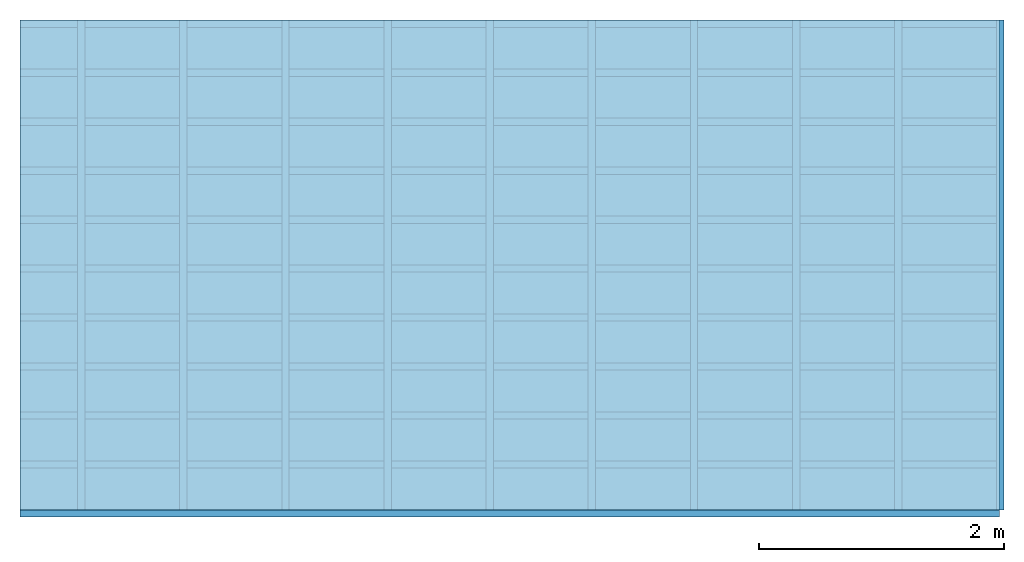
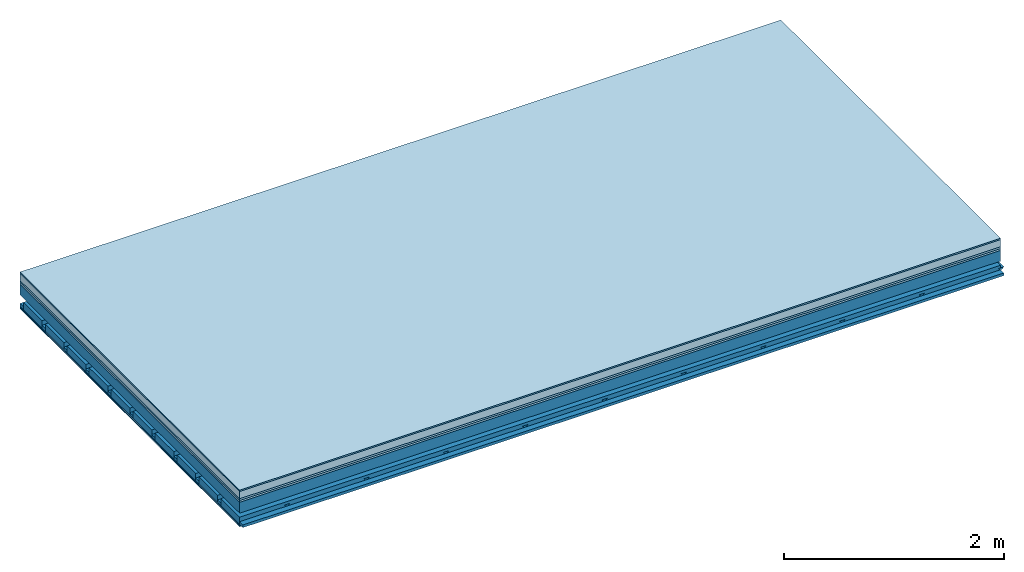
# One storey: 7 plates, 4 members, 1 element without a shape of its own.
"""IFC4 building model written with IfcOpenShell, lengths in metres."""

from ifc_helpers import new_model, si_unit, derived_unit, direction, frame, frame_2d, origin, origin_with_axes, place, context, project, spatial, polyline, rectangle, outline, extrude, material, layer, layer_set, type_object, element, aggregate, save


model = new_model("IFC4")

# Units and contexts
plan_context = context("Plan", 3, precision=1e-05, world=origin(), true_north=direction((0.0, 1.0)))
model_context = context("Model", 3, precision=1e-05, world=origin(), true_north=direction((0.0, 1.0)))
ifc_project = project(units=[si_unit("LENGTHUNIT", "METRE"), derived_unit("SOUNDPRESSUREUNIT", [(si_unit("PRESSUREUNIT", "PASCAL", prefix="MICRO"), 0)]), si_unit("ENERGYUNIT", "JOULE", prefix="MEGA"), si_unit("MASSUNIT", "GRAM", prefix="KILO"), derived_unit("THERMALTRANSMITTANCEUNIT", [(si_unit("POWERUNIT", "WATT"), 1), (si_unit("AREAUNIT", "SQUARE_METRE"), -1), (si_unit("THERMODYNAMICTEMPERATUREUNIT", "KELVIN"), -1)]), derived_unit("AREADENSITYUNIT", [(si_unit("MASSUNIT", "GRAM", prefix="KILO"), 1), (si_unit("AREAUNIT", "SQUARE_METRE"), -1)]), derived_unit("USERDEFINED", [(si_unit("ENERGYUNIT", "JOULE", prefix="MEGA"), 1), (si_unit("AREAUNIT", "SQUARE_METRE"), -1)])], contexts=[plan_context, model_context])

# Site, building, storey
site = spatial("IfcSite", under=ifc_project)
building_placement = place(None, origin())
building = spatial("IfcBuilding", under=site, at=building_placement)
storey_placement = place(building_placement, origin())
storey = spatial("IfcBuildingStorey", under=building, at=storey_placement)

# Slab, members, plates
ifc_material_1 = material(Category="11.013")
ifc_layer_1 = layer(ifc_material_1, 0.015, Name="Flooring")
ifc_material_2 = material(Name="Cement screed", Category="04.006")
ifc_layer_2 = layer(ifc_material_2, 0.08, Name="On-material")
ifc_material_3 = material(Name="Wood fiber generic product", Category="10.009")
ifc_layer_3 = layer(ifc_material_3, 0.02, Name="Impact sound insulation")
ifc_material_4 = material(Category="10.004")
ifc_layer_4 = layer(ifc_material_4, 0.02, Name="Additional insulation")
ifc_material_5 = material(Name="no composite action")
ifc_layer_5 = layer(ifc_material_5, 0.0, Name="Bond")
ifc_layer_6 = layer(None, 0.12, Name="Supporting structure")
ifc_layer_7 = layer(ifc_material_5, 0.0, Name="Bond")
ifc_layer_8 = layer(None, 0.095, Name="Coupling")
ifc_layer_9 = layer(None, 0.03, Name="Battens / profiles")
ifc_material_6 = material(Name="Plasterboard type A", Category="03.008")
ifc_layer_10 = layer(ifc_material_6, 0.0125, Name="Ceiling covering 1st layer")
ifc_layer_11 = layer(ifc_material_6, 0.0125, Name="Ceiling covering layer 2")
ifc_material_7 = material(Category="04.001")
ifc_layer_12 = layer(ifc_material_7, 0.003, Name="Surface / treatment")
ifc_layer_set = layer_set([ifc_layer_1, ifc_layer_2, ifc_layer_3, ifc_layer_4, ifc_layer_5, ifc_layer_6, ifc_layer_7, ifc_layer_8, ifc_layer_9, ifc_layer_10, ifc_layer_11, ifc_layer_12])
slab_type = type_object("IfcSlabType", Name="A2150", PredefinedType="NOTDEFINED", material=ifc_layer_set)
slab_placement = place(None, frame((0.0, 0.0, 0.0), z_axis=(0.0, 0.0, -1.0), x_axis=(1.0, 0.0, 0.0)))
slab = element("IfcSlab", 1, at=slab_placement, inside=storey, type_object=slab_type, material=ifc_layer_set, Name="Slab #1")
ifc_material_8 = material(Name="Solid timber panel")
member_1_placement = place(slab_placement, origin())
member_1 = element("IfcMember", 2, at=member_1_placement, material=ifc_material_8, Name="Supporting structure", context=plan_context, shape_type="SweptSolid", body=[
    extrude(rectangle(XDim=1.0, YDim=0.12, at=frame_2d((0.5, 0.06), x_axis=(1.0, 0.0))), frame((0.0, 4.0, 0.135), z_axis=(0.0, -1.0, 0.0), x_axis=(1.0, 0.0, 0.0)), (0.0, 0.0, 1.0), 4.0),
    extrude(rectangle(XDim=1.0, YDim=0.12, at=frame_2d((0.5, 0.06), x_axis=(1.0, 0.0))), frame((1.0, 4.0, 0.135), z_axis=(0.0, -1.0, 0.0), x_axis=(1.0, 0.0, 0.0)), (0.0, 0.0, 1.0), 4.0),
    extrude(rectangle(XDim=1.0, YDim=0.12, at=frame_2d((0.5, 0.06), x_axis=(1.0, 0.0))), frame((2.0, 4.0, 0.135), z_axis=(0.0, -1.0, 0.0), x_axis=(1.0, 0.0, 0.0)), (0.0, 0.0, 1.0), 4.0),
    extrude(rectangle(XDim=1.0, YDim=0.12, at=frame_2d((0.5, 0.06), x_axis=(1.0, 0.0))), frame((3.0, 4.0, 0.135), z_axis=(0.0, -1.0, 0.0), x_axis=(1.0, 0.0, 0.0)), (0.0, 0.0, 1.0), 4.0),
    extrude(rectangle(XDim=1.0, YDim=0.12, at=frame_2d((0.5, 0.06), x_axis=(1.0, 0.0))), frame((4.0, 4.0, 0.135), z_axis=(0.0, -1.0, 0.0), x_axis=(1.0, 0.0, 0.0)), (0.0, 0.0, 1.0), 4.0),
    extrude(rectangle(XDim=1.0, YDim=0.12, at=frame_2d((0.5, 0.06), x_axis=(1.0, 0.0))), frame((5.0, 4.0, 0.135), z_axis=(0.0, -1.0, 0.0), x_axis=(1.0, 0.0, 0.0)), (0.0, 0.0, 1.0), 4.0),
    extrude(rectangle(XDim=1.0, YDim=0.12, at=frame_2d((0.5, 0.06), x_axis=(1.0, 0.0))), frame((6.0, 4.0, 0.135), z_axis=(0.0, -1.0, 0.0), x_axis=(1.0, 0.0, 0.0)), (0.0, 0.0, 1.0), 4.0),
    extrude(rectangle(XDim=1.0, YDim=0.12, at=frame_2d((0.5, 0.06), x_axis=(1.0, 0.0))), frame((7.0, 4.0, 0.135), z_axis=(0.0, -1.0, 0.0), x_axis=(1.0, 0.0, 0.0)), (0.0, 0.0, 1.0), 4.0),
])
ifc_material_9 = material()
member_2_placement = place(slab_placement, origin())
member_2 = element("IfcMember", 3, at=member_2_placement, material=ifc_material_9, Name="Coupling", context=plan_context, shape_type="SweptSolid", body=[
    extrude(outline(polyline([(0.0, 0.0), (0.06, 0.0), (0.04, 0.02), (0.02, 0.02), (0.0, 0.0)])), frame((0.47, 4.0, 0.33), z_axis=(0.0, -1.0, 0.0), x_axis=(1.0, 0.0, 0.0)), (0.0, 0.0, 1.0), 4.0),
    extrude(outline(polyline([(0.0, 0.0), (0.06, 0.0), (0.04, 0.02), (0.02, 0.02), (0.0, 0.0)])), frame((1.304, 4.0, 0.33), z_axis=(0.0, -1.0, 0.0), x_axis=(1.0, 0.0, 0.0)), (0.0, 0.0, 1.0), 4.0),
    extrude(outline(polyline([(0.0, 0.0), (0.06, 0.0), (0.04, 0.02), (0.02, 0.02), (0.0, 0.0)])), frame((2.138, 4.0, 0.33), z_axis=(0.0, -1.0, 0.0), x_axis=(1.0, 0.0, 0.0)), (0.0, 0.0, 1.0), 4.0),
    extrude(outline(polyline([(0.0, 0.0), (0.06, 0.0), (0.04, 0.02), (0.02, 0.02), (0.0, 0.0)])), frame((2.972, 4.0, 0.33), z_axis=(0.0, -1.0, 0.0), x_axis=(1.0, 0.0, 0.0)), (0.0, 0.0, 1.0), 4.0),
    extrude(outline(polyline([(0.0, 0.0), (0.06, 0.0), (0.04, 0.02), (0.02, 0.02), (0.0, 0.0)])), frame((3.806, 4.0, 0.33), z_axis=(0.0, -1.0, 0.0), x_axis=(1.0, 0.0, 0.0)), (0.0, 0.0, 1.0), 4.0),
    extrude(outline(polyline([(0.0, 0.0), (0.06, 0.0), (0.04, 0.02), (0.02, 0.02), (0.0, 0.0)])), frame((4.64, 4.0, 0.33), z_axis=(0.0, -1.0, 0.0), x_axis=(1.0, 0.0, 0.0)), (0.0, 0.0, 1.0), 4.0),
    extrude(outline(polyline([(0.0, 0.0), (0.06, 0.0), (0.04, 0.02), (0.02, 0.02), (0.0, 0.0)])), frame((5.474, 4.0, 0.33), z_axis=(0.0, -1.0, 0.0), x_axis=(1.0, 0.0, 0.0)), (0.0, 0.0, 1.0), 4.0),
    extrude(outline(polyline([(0.0, 0.0), (0.06, 0.0), (0.04, 0.02), (0.02, 0.02), (0.0, 0.0)])), frame((6.308, 4.0, 0.33), z_axis=(0.0, -1.0, 0.0), x_axis=(1.0, 0.0, 0.0)), (0.0, 0.0, 1.0), 4.0),
    extrude(outline(polyline([(0.0, 0.0), (0.06, 0.0), (0.04, 0.02), (0.02, 0.02), (0.0, 0.0)])), frame((7.142, 4.0, 0.33), z_axis=(0.0, -1.0, 0.0), x_axis=(1.0, 0.0, 0.0)), (0.0, 0.0, 1.0), 4.0),
    extrude(outline(polyline([(0.0, 0.0), (0.06, 0.0), (0.04, 0.02), (0.02, 0.02), (0.0, 0.0)])), frame((7.976, 4.0, 0.33), z_axis=(0.0, -1.0, 0.0), x_axis=(1.0, 0.0, 0.0)), (0.0, 0.0, 1.0), 4.0),
])
member_3_placement = place(slab_placement, origin())
member_3 = element("IfcMember", 4, at=member_3_placement, material=ifc_material_9, Name="Battens / profiles", context=plan_context, shape_type="SweptSolid", body=[
    extrude(rectangle(XDim=0.06, YDim=0.03, at=frame_2d((0.03, 0.015), x_axis=(1.0, 0.0))), frame((0.0, 0.0, 0.35), z_axis=(1.0, 0.0, 0.0), x_axis=(0.0, 1.0, 0.0)), (0.0, 0.0, 1.0), 8.0),
    extrude(rectangle(XDim=0.06, YDim=0.03, at=frame_2d((0.03, 0.015), x_axis=(1.0, 0.0))), frame((0.0, 0.4, 0.35), z_axis=(1.0, 0.0, 0.0), x_axis=(0.0, 1.0, 0.0)), (0.0, 0.0, 1.0), 8.0),
    extrude(rectangle(XDim=0.06, YDim=0.03, at=frame_2d((0.03, 0.015), x_axis=(1.0, 0.0))), frame((0.0, 0.8, 0.35), z_axis=(1.0, 0.0, 0.0), x_axis=(0.0, 1.0, 0.0)), (0.0, 0.0, 1.0), 8.0),
    extrude(rectangle(XDim=0.06, YDim=0.03, at=frame_2d((0.03, 0.015), x_axis=(1.0, 0.0))), frame((0.0, 1.2, 0.35), z_axis=(1.0, 0.0, 0.0), x_axis=(0.0, 1.0, 0.0)), (0.0, 0.0, 1.0), 8.0),
    extrude(rectangle(XDim=0.06, YDim=0.03, at=frame_2d((0.03, 0.015), x_axis=(1.0, 0.0))), frame((0.0, 1.6, 0.35), z_axis=(1.0, 0.0, 0.0), x_axis=(0.0, 1.0, 0.0)), (0.0, 0.0, 1.0), 8.0),
    extrude(rectangle(XDim=0.06, YDim=0.03, at=frame_2d((0.03, 0.015), x_axis=(1.0, 0.0))), frame((0.0, 2.0, 0.35), z_axis=(1.0, 0.0, 0.0), x_axis=(0.0, 1.0, 0.0)), (0.0, 0.0, 1.0), 8.0),
    extrude(rectangle(XDim=0.06, YDim=0.03, at=frame_2d((0.03, 0.015), x_axis=(1.0, 0.0))), frame((0.0, 2.4, 0.35), z_axis=(1.0, 0.0, 0.0), x_axis=(0.0, 1.0, 0.0)), (0.0, 0.0, 1.0), 8.0),
    extrude(rectangle(XDim=0.06, YDim=0.03, at=frame_2d((0.03, 0.015), x_axis=(1.0, 0.0))), frame((0.0, 2.8, 0.35), z_axis=(1.0, 0.0, 0.0), x_axis=(0.0, 1.0, 0.0)), (0.0, 0.0, 1.0), 8.0),
    extrude(rectangle(XDim=0.06, YDim=0.03, at=frame_2d((0.03, 0.015), x_axis=(1.0, 0.0))), frame((0.0, 3.2, 0.35), z_axis=(1.0, 0.0, 0.0), x_axis=(0.0, 1.0, 0.0)), (0.0, 0.0, 1.0), 8.0),
    extrude(rectangle(XDim=0.06, YDim=0.03, at=frame_2d((0.03, 0.015), x_axis=(1.0, 0.0))), frame((0.0, 3.6, 0.35), z_axis=(1.0, 0.0, 0.0), x_axis=(0.0, 1.0, 0.0)), (0.0, 0.0, 1.0), 8.0),
    extrude(rectangle(XDim=0.06, YDim=0.03, at=frame_2d((0.03, 0.015), x_axis=(1.0, 0.0))), frame((0.0, 4.0, 0.35), z_axis=(1.0, 0.0, 0.0), x_axis=(0.0, 1.0, 0.0)), (0.0, 0.0, 1.0), 8.0),
])
ifc_material_10 = material()
member_4_placement = place(slab_placement, origin())
member_4 = element("IfcMember", 5, at=member_4_placement, material=ifc_material_10, Name="Cavity", context=plan_context, shape_type="SweptSolid", body=[
    extrude(rectangle(XDim=0.34, YDim=0.08, at=frame_2d((0.17, 0.04), x_axis=(1.0, 0.0))), frame((0.0, 0.06, 0.3), z_axis=(1.0, 0.0, 0.0), x_axis=(0.0, 1.0, 0.0)), (0.0, 0.0, 1.0), 8.0),
    extrude(rectangle(XDim=0.34, YDim=0.08, at=frame_2d((0.17, 0.04), x_axis=(1.0, 0.0))), frame((0.0, 0.46, 0.3), z_axis=(1.0, 0.0, 0.0), x_axis=(0.0, 1.0, 0.0)), (0.0, 0.0, 1.0), 8.0),
    extrude(rectangle(XDim=0.34, YDim=0.08, at=frame_2d((0.17, 0.04), x_axis=(1.0, 0.0))), frame((0.0, 0.86, 0.3), z_axis=(1.0, 0.0, 0.0), x_axis=(0.0, 1.0, 0.0)), (0.0, 0.0, 1.0), 8.0),
    extrude(rectangle(XDim=0.34, YDim=0.08, at=frame_2d((0.17, 0.04), x_axis=(1.0, 0.0))), frame((0.0, 1.26, 0.3), z_axis=(1.0, 0.0, 0.0), x_axis=(0.0, 1.0, 0.0)), (0.0, 0.0, 1.0), 8.0),
    extrude(rectangle(XDim=0.34, YDim=0.08, at=frame_2d((0.17, 0.04), x_axis=(1.0, 0.0))), frame((0.0, 1.66, 0.3), z_axis=(1.0, 0.0, 0.0), x_axis=(0.0, 1.0, 0.0)), (0.0, 0.0, 1.0), 8.0),
    extrude(rectangle(XDim=0.34, YDim=0.08, at=frame_2d((0.17, 0.04), x_axis=(1.0, 0.0))), frame((0.0, 2.06, 0.3), z_axis=(1.0, 0.0, 0.0), x_axis=(0.0, 1.0, 0.0)), (0.0, 0.0, 1.0), 8.0),
    extrude(rectangle(XDim=0.34, YDim=0.08, at=frame_2d((0.17, 0.04), x_axis=(1.0, 0.0))), frame((0.0, 2.46, 0.3), z_axis=(1.0, 0.0, 0.0), x_axis=(0.0, 1.0, 0.0)), (0.0, 0.0, 1.0), 8.0),
    extrude(rectangle(XDim=0.34, YDim=0.08, at=frame_2d((0.17, 0.04), x_axis=(1.0, 0.0))), frame((0.0, 2.86, 0.3), z_axis=(1.0, 0.0, 0.0), x_axis=(0.0, 1.0, 0.0)), (0.0, 0.0, 1.0), 8.0),
    extrude(rectangle(XDim=0.34, YDim=0.08, at=frame_2d((0.17, 0.04), x_axis=(1.0, 0.0))), frame((0.0, 3.26, 0.3), z_axis=(1.0, 0.0, 0.0), x_axis=(0.0, 1.0, 0.0)), (0.0, 0.0, 1.0), 8.0),
    extrude(rectangle(XDim=0.34, YDim=0.08, at=frame_2d((0.17, 0.04), x_axis=(1.0, 0.0))), frame((0.0, 3.66, 0.3), z_axis=(1.0, 0.0, 0.0), x_axis=(0.0, 1.0, 0.0)), (0.0, 0.0, 1.0), 8.0),
])
plate_1_placement = place(slab_placement, origin())
plate_1 = element("IfcPlate", 6, at=plate_1_placement, material=ifc_material_1, Name="Flooring", context=plan_context, shape_type="SweptSolid", body=[
    extrude(rectangle(XDim=8.0, YDim=4.0, at=frame_2d((4.0, 2.0), x_axis=(1.0, 0.0))), origin_with_axes(), (0.0, 0.0, 1.0), 0.015),
])
plate_2_placement = place(slab_placement, origin())
plate_2 = element("IfcPlate", 7, at=plate_2_placement, material=ifc_material_2, Name="On-material", context=plan_context, shape_type="SweptSolid", body=[
    extrude(rectangle(XDim=8.0, YDim=4.0, at=frame_2d((4.0, 2.0), x_axis=(1.0, 0.0))), frame((0.0, 0.0, 0.015), z_axis=(0.0, 0.0, 1.0), x_axis=(1.0, 0.0, 0.0)), (0.0, 0.0, 1.0), 0.08),
])
plate_3_placement = place(slab_placement, origin())
plate_3 = element("IfcPlate", 8, at=plate_3_placement, material=ifc_material_3, Name="Impact sound insulation", context=plan_context, shape_type="SweptSolid", body=[
    extrude(rectangle(XDim=8.0, YDim=4.0, at=frame_2d((4.0, 2.0), x_axis=(1.0, 0.0))), frame((0.0, 0.0, 0.095), z_axis=(0.0, 0.0, 1.0), x_axis=(1.0, 0.0, 0.0)), (0.0, 0.0, 1.0), 0.02),
])
plate_4_placement = place(slab_placement, origin())
plate_4 = element("IfcPlate", 9, at=plate_4_placement, material=ifc_material_4, Name="Additional insulation", context=plan_context, shape_type="SweptSolid", body=[
    extrude(rectangle(XDim=8.0, YDim=4.0, at=frame_2d((4.0, 2.0), x_axis=(1.0, 0.0))), frame((0.0, 0.0, 0.115), z_axis=(0.0, 0.0, 1.0), x_axis=(1.0, 0.0, 0.0)), (0.0, 0.0, 1.0), 0.02),
])
plate_5_placement = place(slab_placement, origin())
plate_5 = element("IfcPlate", 10, at=plate_5_placement, material=ifc_material_6, Name="Ceiling covering 1st layer", context=plan_context, shape_type="SweptSolid", body=[
    extrude(rectangle(XDim=8.0, YDim=4.0, at=frame_2d((4.0, 2.0), x_axis=(1.0, 0.0))), frame((0.0, 0.0, 0.38), z_axis=(0.0, 0.0, 1.0), x_axis=(1.0, 0.0, 0.0)), (0.0, 0.0, 1.0), 0.0125),
])
plate_6_placement = place(slab_placement, origin())
plate_6 = element("IfcPlate", 11, at=plate_6_placement, material=ifc_material_6, Name="Ceiling covering layer 2", context=plan_context, shape_type="SweptSolid", body=[
    extrude(rectangle(XDim=8.0, YDim=4.0, at=frame_2d((4.0, 2.0), x_axis=(1.0, 0.0))), frame((0.0, 0.0, 0.3925), z_axis=(0.0, 0.0, 1.0), x_axis=(1.0, 0.0, 0.0)), (0.0, 0.0, 1.0), 0.0125),
])
plate_7_placement = place(slab_placement, origin())
plate_7 = element("IfcPlate", 12, at=plate_7_placement, material=ifc_material_7, Name="Surface / treatment", context=plan_context, shape_type="SweptSolid", body=[
    extrude(rectangle(XDim=8.0, YDim=4.0, at=frame_2d((4.0, 2.0), x_axis=(1.0, 0.0))), frame((0.0, 0.0, 0.405), z_axis=(0.0, 0.0, 1.0), x_axis=(1.0, 0.0, 0.0)), (0.0, 0.0, 1.0), 0.003),
])
aggregate(slab, [plate_1, plate_2, plate_3, plate_4, member_1, member_2, member_3, member_4, plate_5, plate_6, plate_7])

save(model, "model.ifc")
